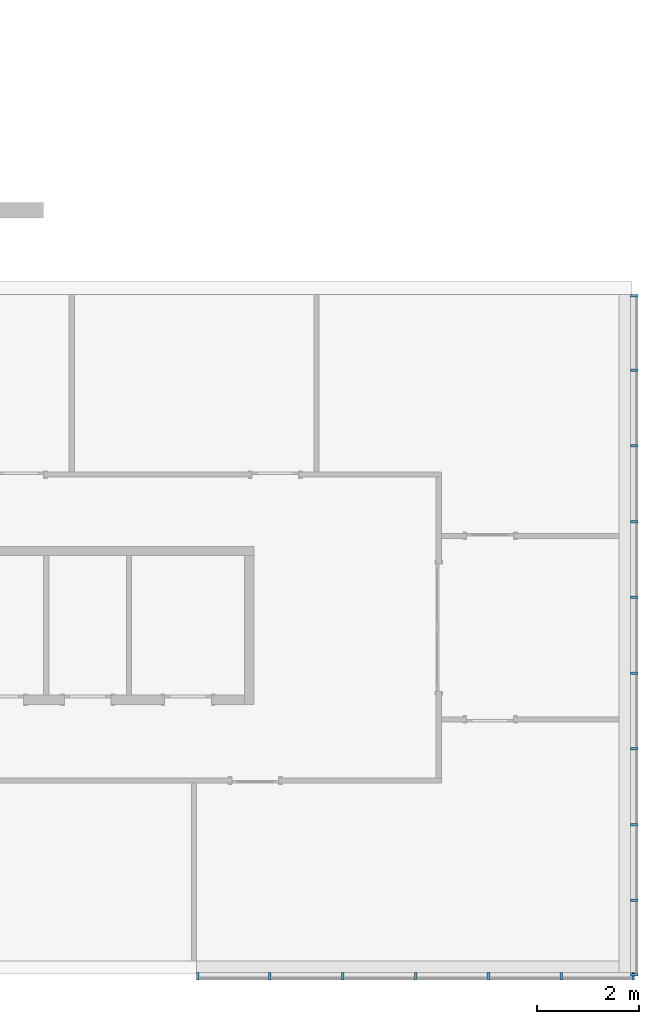
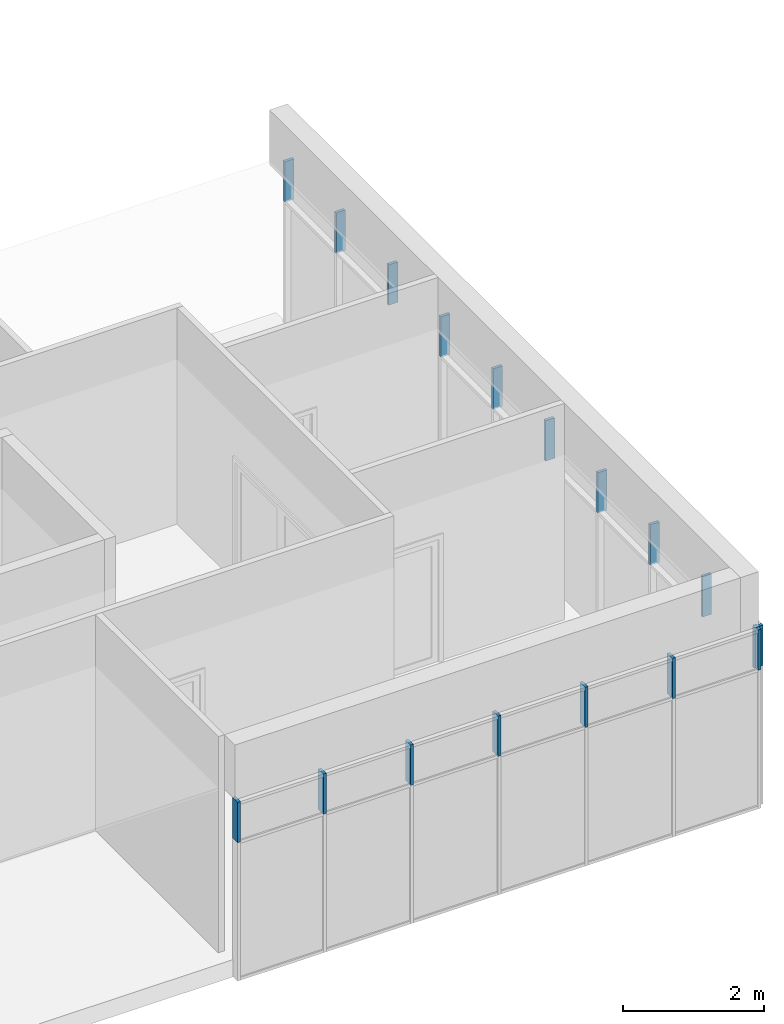
# One storey, part 5 of 11: 17 members, 2 elements without a shape of their own.
"""IFC2X3 building model written with IfcOpenShell, lengths in millimetres."""

from ifc_helpers import new_model, entity, si_unit, converted_unit, direction, frame, frame_2d, origin, origin_2d_with_axis, place, context, subcontext, project, spatial, rectangle, extrude, element, aggregate, save


model = new_model("IFC2X3")

# Units and contexts
model_context = context("Model", 3, precision=1e-06, world=origin(), true_north=direction((2.0, 6.12303176911189e-17, 1.0)))
context_of_model = context(None, 3, precision=1e-06, world=origin(), true_north=direction((2.0, 6.12303176911189e-17, 1.0)))
body_context = subcontext(model_context, "Body", "Model", "MODEL_VIEW")
ifc_project = project(units=[si_unit("LENGTHUNIT", "METRE", prefix="MILLI"), si_unit("AREAUNIT", "SQUARE_METRE", prefix="MILLI"), si_unit("VOLUMEUNIT", "CUBIC_METRE", prefix="MILLI"), converted_unit("PLANEANGLEUNIT", "DEGREE", entity("IfcRatioMeasure", 0.0174532925199433), si_unit("PLANEANGLEUNIT", "RADIAN"), dimensions=[0, 0, 0, 0, 0, 0, 0]), si_unit("TIMEUNIT", "SECOND")], contexts=[model_context, context_of_model])

# Site, building, storey
site_placement = place(None, origin())
site = spatial("IfcSite", under=ifc_project, at=site_placement, CompositionType="ELEMENT")
building_placement = place(site_placement, origin())
building = spatial("IfcBuilding", under=site, at=building_placement, CompositionType="ELEMENT")
storey_placement = place(building_placement, frame((0.0, 0.0, 3750.0)))
storey = spatial("IfcBuildingStorey", under=building, at=storey_placement, Name="02. 2 etg.", CompositionType="ELEMENT", Elevation=3750.00000000068)

# Curtain wall, members
curtain_wall_1_placement = place(storey_placement, origin())
curtain_wall_1 = element("IfcCurtainWall", 1, at=curtain_wall_1_placement, inside=storey, Name="Curtain Wall:Storefront", ObjectType="Curtain Wall:Storefront")
member_1_placement = place(storey_placement, origin())
member_1 = element("IfcMember", 2, at=member_1_placement, Name="Curtain Wall:Storefront:8486", ObjectType="Curtain Wall:Storefront:8486", context=body_context, shape_type="SweptSolid", body=[
    extrude(rectangle(XDim=50.0, YDim=150.000000000001, at=origin_2d_with_axis()), frame((41098.2357123495, -85.0, 2100.0), z_axis=(0.0, 0.0, 1.0), x_axis=(0.0, -1.0, 0.0)), (0.0, 0.0, 1.0), 700.000000000001),
])
member_2_placement = place(storey_placement, origin())
member_2 = element("IfcMember", 3, at=member_2_placement, Name="Curtain Wall:Storefront:8486", ObjectType="Curtain Wall:Storefront:8486", context=body_context, shape_type="SweptSolid", body=[
    extrude(rectangle(XDim=150.000000000001, YDim=49.9999999999995, at=frame_2d((0.0, -1.08357767203415e-12), x_axis=(1.0, 0.0))), frame((41098.2357123495, -13415.0, 2100.0)), (0.0, 0.0, 1.0), 700.000000000001),
])
member_3_placement = place(storey_placement, origin())
member_3 = element("IfcMember", 4, at=member_3_placement, Name="Curtain Wall:Storefront:8486", ObjectType="Curtain Wall:Storefront:8486", context=body_context, shape_type="SweptSolid", body=[
    extrude(rectangle(XDim=150.000000000001, YDim=50.0, at=origin_2d_with_axis()), frame((41098.2357123495, -1546.66666666667, 2100.0)), (0.0, 0.0, 1.0), 700.000000000001),
])
member_4_placement = place(storey_placement, origin())
member_4 = element("IfcMember", 5, at=member_4_placement, Name="Curtain Wall:Storefront:8486", ObjectType="Curtain Wall:Storefront:8486", context=body_context, shape_type="SweptSolid", body=[
    extrude(rectangle(XDim=150.000000000001, YDim=50.0, at=origin_2d_with_axis()), frame((41098.2357123495, -3033.33333333333, 2100.0)), (0.0, 0.0, 1.0), 700.000000000001),
])
member_5_placement = place(storey_placement, origin())
member_5 = element("IfcMember", 6, at=member_5_placement, Name="Curtain Wall:Storefront:8486", ObjectType="Curtain Wall:Storefront:8486", context=body_context, shape_type="SweptSolid", body=[
    extrude(rectangle(XDim=150.000000000001, YDim=50.0, at=origin_2d_with_axis()), frame((41098.2357123495, -4520.0, 2100.0)), (0.0, 0.0, 1.0), 700.000000000001),
])
member_6_placement = place(storey_placement, origin())
member_6 = element("IfcMember", 7, at=member_6_placement, Name="Curtain Wall:Storefront:8486", ObjectType="Curtain Wall:Storefront:8486", context=body_context, shape_type="SweptSolid", body=[
    extrude(rectangle(XDim=150.000000000001, YDim=49.9999999999995, at=origin_2d_with_axis()), frame((41098.2357123495, -6006.66666666667, 2100.0)), (0.0, 0.0, 1.0), 700.000000000001),
])
member_7_placement = place(storey_placement, origin())
member_7 = element("IfcMember", 8, at=member_7_placement, Name="Curtain Wall:Storefront:8486", ObjectType="Curtain Wall:Storefront:8486", context=body_context, shape_type="SweptSolid", body=[
    extrude(rectangle(XDim=150.000000000001, YDim=49.9999999999995, at=origin_2d_with_axis()), frame((41098.2357123495, -7493.33333333333, 2100.0)), (0.0, 0.0, 1.0), 700.000000000001),
])
member_8_placement = place(storey_placement, origin())
member_8 = element("IfcMember", 9, at=member_8_placement, Name="Curtain Wall:Storefront:8486", ObjectType="Curtain Wall:Storefront:8486", context=body_context, shape_type="SweptSolid", body=[
    extrude(rectangle(XDim=150.000000000001, YDim=49.9999999999995, at=origin_2d_with_axis()), frame((41098.2357123495, -8980.0, 2100.0)), (0.0, 0.0, 1.0), 700.000000000001),
])
member_9_placement = place(storey_placement, origin())
member_9 = element("IfcMember", 10, at=member_9_placement, Name="Curtain Wall:Storefront:8486", ObjectType="Curtain Wall:Storefront:8486", context=body_context, shape_type="SweptSolid", body=[
    extrude(rectangle(XDim=150.000000000001, YDim=50.0000000000016, at=origin_2d_with_axis()), frame((41098.2357123495, -10466.6666666667, 2100.0)), (0.0, 0.0, 1.0), 700.000000000001),
])
member_10_placement = place(storey_placement, origin())
member_10 = element("IfcMember", 11, at=member_10_placement, Name="Curtain Wall:Storefront:8486", ObjectType="Curtain Wall:Storefront:8486", context=body_context, shape_type="SweptSolid", body=[
    extrude(rectangle(XDim=150.000000000001, YDim=50.0000000000016, at=origin_2d_with_axis()), frame((41098.2357123495, -11953.3333333333, 2100.0)), (0.0, 0.0, 1.0), 700.000000000001),
])
aggregate(curtain_wall_1, [member_1, member_2, member_3, member_4, member_5, member_6, member_7, member_8, member_9, member_10])

curtain_wall_2_placement = place(storey_placement, origin())
curtain_wall_2 = element("IfcCurtainWall", 12, at=curtain_wall_2_placement, inside=storey, Name="Curtain Wall:Storefront", ObjectType="Curtain Wall:Storefront")
member_11_placement = place(storey_placement, origin())
member_11 = element("IfcMember", 13, at=member_11_placement, Name="Curtain Wall:Storefront:8486", ObjectType="Curtain Wall:Storefront:8486", context=body_context, shape_type="SweptSolid", body=[
    extrude(rectangle(XDim=49.9999999999973, YDim=150.000000000001, at=frame_2d((4.33253433129721e-12, 0.0), x_axis=(1.0, 0.0))), frame((41073.2357123495, -13440.0, 2100.0), z_axis=(0.0, 0.0, 1.0), x_axis=(-1.0, 0.0, 0.0)), (0.0, 0.0, 1.0), 700.000000000001),
])
member_12_placement = place(storey_placement, origin())
member_12 = element("IfcMember", 14, at=member_12_placement, Name="Curtain Wall:Storefront:8486", ObjectType="Curtain Wall:Storefront:8486", context=body_context, shape_type="SweptSolid", body=[
    extrude(rectangle(XDim=150.000000000001, YDim=50.0000000000016, at=frame_2d((-1.08002495835535e-12, -2.16715534406831e-12), x_axis=(1.0, 0.0))), frame((32533.2357123495, -13440.0, 2100.0), z_axis=(0.0, 0.0, 1.0), x_axis=(0.0, -1.0, 0.0)), (0.0, 0.0, 1.0), 700.000000000001),
])
member_13_placement = place(storey_placement, origin())
member_13 = element("IfcMember", 15, at=member_13_placement, Name="Curtain Wall:Storefront:8486", ObjectType="Curtain Wall:Storefront:8486", context=body_context, shape_type="SweptSolid", body=[
    extrude(rectangle(XDim=150.000000000001, YDim=50.000000000006, at=frame_2d((-1.08002495835535e-12, 0.0), x_axis=(1.0, 0.0))), frame((39666.5690456828, -13440.0, 2100.0), z_axis=(0.0, 0.0, 1.0), x_axis=(0.0, -1.0, 0.0)), (0.0, 0.0, 1.0), 700.000000000001),
])
member_14_placement = place(storey_placement, origin())
member_14 = element("IfcMember", 16, at=member_14_placement, Name="Curtain Wall:Storefront:8486", ObjectType="Curtain Wall:Storefront:8486", context=body_context, shape_type="SweptSolid", body=[
    extrude(rectangle(XDim=150.000000000001, YDim=49.9999999999973, at=frame_2d((-1.08002495835535e-12, 0.0), x_axis=(1.0, 0.0))), frame((38234.9023790161, -13440.0, 2100.0), z_axis=(0.0, 0.0, 1.0), x_axis=(0.0, -1.0, 0.0)), (0.0, 0.0, 1.0), 700.000000000001),
])
member_15_placement = place(storey_placement, origin())
member_15 = element("IfcMember", 17, at=member_15_placement, Name="Curtain Wall:Storefront:8486", ObjectType="Curtain Wall:Storefront:8486", context=body_context, shape_type="SweptSolid", body=[
    extrude(rectangle(XDim=150.000000000001, YDim=49.9999999999973, at=frame_2d((-1.08002495835535e-12, 0.0), x_axis=(1.0, 0.0))), frame((36803.2357123495, -13440.0, 2100.0), z_axis=(0.0, 0.0, 1.0), x_axis=(0.0, -1.0, 0.0)), (0.0, 0.0, 1.0), 700.000000000001),
])
member_16_placement = place(storey_placement, origin())
member_16 = element("IfcMember", 18, at=member_16_placement, Name="Curtain Wall:Storefront:8486", ObjectType="Curtain Wall:Storefront:8486", context=body_context, shape_type="SweptSolid", body=[
    extrude(rectangle(XDim=150.000000000001, YDim=49.9999999999973, at=frame_2d((-1.08002495835535e-12, 0.0), x_axis=(1.0, 0.0))), frame((35371.5690456828, -13440.0, 2100.0), z_axis=(0.0, 0.0, 1.0), x_axis=(0.0, -1.0, 0.0)), (0.0, 0.0, 1.0), 700.000000000001),
])
member_17_placement = place(storey_placement, origin())
member_17 = element("IfcMember", 19, at=member_17_placement, Name="Curtain Wall:Storefront:8486", ObjectType="Curtain Wall:Storefront:8486", context=body_context, shape_type="SweptSolid", body=[
    extrude(rectangle(XDim=150.000000000001, YDim=49.9999999999973, at=frame_2d((-1.08002495835535e-12, 0.0), x_axis=(1.0, 0.0))), frame((33939.9023790161, -13440.0, 2100.0), z_axis=(0.0, 0.0, 1.0), x_axis=(0.0, -1.0, 0.0)), (0.0, 0.0, 1.0), 700.000000000001),
])
aggregate(curtain_wall_2, [member_11, member_12, member_13, member_14, member_15, member_16, member_17])

save(model, "model.ifc")
